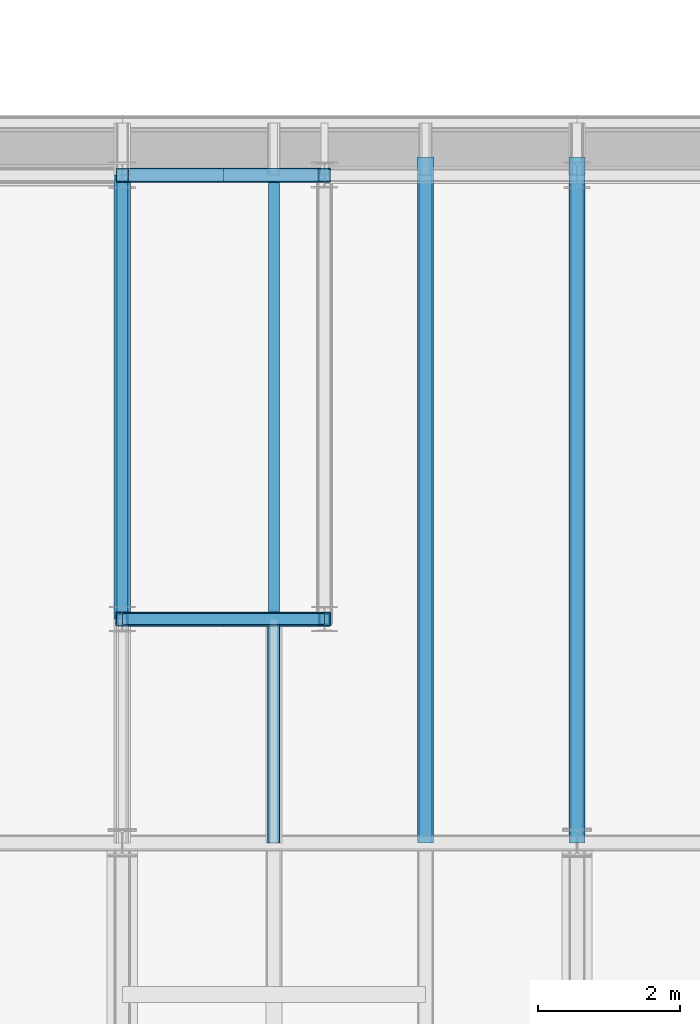
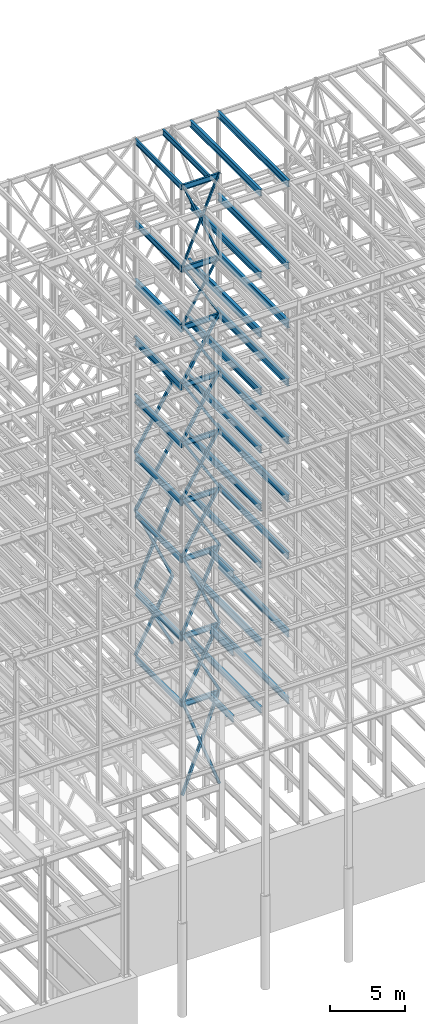
# One storey, part 141 of 150: 67 beams.
"""IFC2X3 building model written with IfcOpenShell, lengths in millimetres."""

import ifcopenshell
import ifcopenshell.guid

model = None  # the IFC model being written
_history = None  # IfcOwnerHistory: only IFC2X3 demands one
_inside = {}  # id of a spatial element -> (the spatial element, [elements in it])
_under = {}  # id of a project, library or spatial element -> (it, [spatial elements below it])
_declared = {}  # id of a project -> (the project, [libraries it declares])
_typed = {}  # id of a type object -> (the type object, [elements of that type])
_made_of = {}  # id of a material, layer set ... -> (it, [elements and type objects made of it])


def new_model(schema):
    """Start an empty IFC model of exactly this schema.

    Asked for "IFC4X3", IfcOpenShell would pick the latest addendum, in which some entities
    have other attributes; the version numbers below select the first issue.
    IFC2X3 requires an IfcOwnerHistory on every rooted entity: one is made here for all.
    """
    global model, _history
    if schema == "IFC4X3":
        model = ifcopenshell.file(schema_version=(4, 3, 0, 0))
    else:
        model = ifcopenshell.file(schema=schema)
    _inside.clear()
    _under.clear()
    _declared.clear()
    _typed.clear()
    _made_of.clear()
    _history = None
    if model.schema == "IFC2X3":
        org = make("IfcOrganization", Name="unknown")
        user = make(
            "IfcPersonAndOrganization",
            ThePerson=make("IfcPerson", FamilyName="unknown"),
            TheOrganization=org,
        )
        app = make(
            "IfcApplication",
            ApplicationDeveloper=org,
            Version="unknown",
            ApplicationFullName="unknown",
            ApplicationIdentifier="unknown",
        )
        _history = make(
            "IfcOwnerHistory",
            OwningUser=user,
            OwningApplication=app,
            ChangeAction="ADDED",
            CreationDate=0,
        )
    return model


def make(cls, **values):
    """One entity of the class cls with the attributes given. An attribute that is None is left unset."""
    return model.create_entity(
        cls, **{name: value for name, value in values.items() if value is not None}
    )


def rooted(cls, **values):
    """An entity with a GlobalId (a new one), such as an element, a storey or a relation."""
    return make(cls, GlobalId=ifcopenshell.guid.new(), OwnerHistory=_history, **values)


def si_unit(unit_type, name, prefix=None):
    """IfcSIUnit, for example si_unit("LENGTHUNIT", "METRE", prefix="MILLI")."""
    return make("IfcSIUnit", UnitType=unit_type, Prefix=prefix, Name=name)


def assignment(units):
    """IfcUnitAssignment: the units of a project."""
    return None if units is None else make("IfcUnitAssignment", Units=units)


def point(xyz):
    """IfcCartesianPoint."""
    return None if xyz is None else make("IfcCartesianPoint", Coordinates=xyz)


def direction(xyz):
    """IfcDirection."""
    return None if xyz is None else make("IfcDirection", DirectionRatios=xyz)


def frame(location, z_axis=None, x_axis=None):
    """IfcAxis2Placement3D, a coordinate frame: its origin and axes. An axis left out is left unset."""
    return make(
        "IfcAxis2Placement3D",
        Location=point(location),
        Axis=direction(z_axis),
        RefDirection=direction(x_axis),
    )


def frame_2d(location, x_axis=None):
    """IfcAxis2Placement2D, a coordinate frame in the plane: its origin and x axis."""
    return make(
        "IfcAxis2Placement2D", Location=point(location), RefDirection=direction(x_axis)
    )


def origin_with_axes():
    """The frame at (0, 0, 0) with the z axis (0, 0, 1) and the x axis (1, 0, 0) written out."""
    return frame((0.0, 0.0, 0.0), z_axis=(0.0, 0.0, 1.0), x_axis=(1.0, 0.0, 0.0))


def origin_2d_with_axis():
    """The frame at (0, 0) in the plane with the x axis (1, 0) written out."""
    return frame_2d((0.0, 0.0), x_axis=(1.0, 0.0))


def place(relative_to, where):
    """IfcLocalPlacement: puts the frame where relative to a parent placement (None: the world)."""
    return make(
        "IfcLocalPlacement", PlacementRelTo=relative_to, RelativePlacement=where
    )


def context(
    kind, dimensions, precision=None, world=None, true_north=None, identifier=None
):
    """IfcGeometricRepresentationContext, for example the 3D "Model" context."""
    return make(
        "IfcGeometricRepresentationContext",
        ContextIdentifier=identifier,
        ContextType=kind,
        CoordinateSpaceDimension=dimensions,
        Precision=precision,
        WorldCoordinateSystem=world,
        TrueNorth=true_north,
    )


def subcontext(parent, identifier, kind, view, scale=None):
    """IfcGeometricRepresentationSubContext, for example "Body" below "Model"."""
    return make(
        "IfcGeometricRepresentationSubContext",
        ContextIdentifier=identifier,
        ContextType=kind,
        ParentContext=parent,
        TargetScale=scale,
        TargetView=view,
    )


def project(units=None, contexts=None):
    """IfcProject with its units and contexts."""
    return rooted(
        "IfcProject",
        Name="project",
        RepresentationContexts=contexts,
        UnitsInContext=assignment(units),
    )


def spatial(cls, under=None, at=None, **own):
    """A site, building, storey or space (cls), placed at a placement, below another one or the project."""
    s = rooted(cls, ObjectPlacement=at, **own)
    if under is not None:
        _under.setdefault(under.id(), (under, []))[1].append(s)
    return s


def profile(cls, at=None, kind="AREA", **sizes):
    """A parametric profile (cls). Its sizes go by their IFC names, for example OverallWidth=200.0."""
    return make(cls, ProfileType=kind, Position=at, **sizes)


def hollow_rectangle(**sizes):
    """IfcRectangleHollowProfileDef."""
    return profile("IfcRectangleHollowProfileDef", **sizes)


def i_section(**sizes):
    """IfcIShapeProfileDef."""
    return profile("IfcIShapeProfileDef", **sizes)


def extrude(swept, where, along, depth):
    """IfcExtrudedAreaSolid: the profile swept, set in the frame where, extruded along a direction by depth."""
    return make(
        "IfcExtrudedAreaSolid",
        SweptArea=swept,
        Position=where,
        ExtrudedDirection=direction(along),
        Depth=depth,
    )


def shape(context_of_items, identifier, shape_type, items):
    """IfcShapeRepresentation: the items that make up one representation, for example the "Body"."""
    return make(
        "IfcShapeRepresentation",
        ContextOfItems=context_of_items,
        RepresentationIdentifier=identifier,
        RepresentationType=shape_type,
        Items=items,
    )


def material(Name=None, Category=None):
    """IfcMaterial."""
    return make("IfcMaterial", Name=Name, Category=Category)


def made_of(thing, what):
    """Note that an element or type object is made of a material, layer set ...; save() writes the relation."""
    if what is not None:
        _made_of.setdefault(what.id(), (what, []))[1].append(thing)
    return thing


def type_object(cls, material=None, **own):
    """A type object (cls), such as IfcWallType, which elements share."""
    return made_of(rooted(cls, **own), material)


def element(
    cls,
    number,
    at=None,
    inside=None,
    cuts=None,
    type_object=None,
    material=None,
    context=None,
    identifier="Body",
    shape_type=None,
    held_by="IfcProductDefinitionShape",
    body=None,
    shapes=None,
    **own,
):
    """One element of the class cls, such as IfcWall. Its Tag is "e" and its number.

    at: its placement. inside: the storey or other place that contains it. cuts: it is an
    opening in that element (IfcRelVoidsElement). A single representation is given by context,
    identifier, shape_type and body (its items); several are given by shapes. held_by: the class
    of the entity that holds the representations. save() writes the other relations.
    """
    e = rooted(cls, Tag="e%d" % number, ObjectPlacement=at, **own)
    if body is not None:
        shapes = [shape(context, identifier, shape_type, body)]
    if shapes is not None:
        e.Representation = make(held_by, Representations=shapes)
    if inside is not None:
        _inside.setdefault(inside.id(), (inside, []))[1].append(e)
    if cuts is not None:
        rooted(
            "IfcRelVoidsElement", RelatingBuildingElement=cuts, RelatedOpeningElement=e
        )
    if type_object is not None:
        _typed.setdefault(type_object.id(), (type_object, []))[1].append(e)
    return made_of(e, material)


def aggregate(whole, parts):
    """IfcRelAggregates: a whole, such as a stair, and the parts it consists of."""
    return rooted("IfcRelAggregates", RelatingObject=whole, RelatedObjects=parts)


def save(model, path):
    """Write the relations noted so far, then the file.

    IfcRelAggregates (storeys below a building ...), IfcRelContainedInSpatialStructure (elements
    in a storey), IfcRelDefinesByType, IfcRelAssociatesMaterial and IfcRelDeclares: one each for
    every whole, place, type object, material and project.
    """
    for whole, parts in _under.values():
        aggregate(whole, parts)
    for where, things in _inside.values():
        rooted(
            "IfcRelContainedInSpatialStructure",
            RelatedElements=things,
            RelatingStructure=where,
        )
    for kind, things in _typed.values():
        rooted("IfcRelDefinesByType", RelatedObjects=things, RelatingType=kind)
    for what, things in _made_of.values():
        rooted("IfcRelAssociatesMaterial", RelatedObjects=things, RelatingMaterial=what)
    for by, libraries in _declared.values():
        rooted("IfcRelDeclares", RelatingContext=by, RelatedDefinitions=libraries)
    model.write(path)


model = new_model("IFC2X3")

# Units and contexts
model_context = context("Model", 3, precision=1e-05, world=origin_with_axes())
body_context = subcontext(model_context, "Body", "Model", "MODEL_VIEW")
ifc_project = project(units=[si_unit("LENGTHUNIT", "METRE", prefix="MILLI"), si_unit("AREAUNIT", "SQUARE_METRE"), si_unit("VOLUMEUNIT", "CUBIC_METRE"), si_unit("MASSUNIT", "GRAM", prefix="KILO"), si_unit("TIMEUNIT", "SECOND"), si_unit("PLANEANGLEUNIT", "RADIAN"), si_unit("SOLIDANGLEUNIT", "STERADIAN"), si_unit("THERMODYNAMICTEMPERATUREUNIT", "DEGREE_CELSIUS"), si_unit("LUMINOUSINTENSITYUNIT", "LUMEN")], contexts=[model_context])

# Site, building, storey
site_placement = place(None, origin_with_axes())
site = spatial("IfcSite", under=ifc_project, at=site_placement, CompositionType="ELEMENT")
building_placement = place(site_placement, origin_with_axes())
building = spatial("IfcBuilding", under=site, at=building_placement, Name="Undefined", CompositionType="ELEMENT")
storey_placement = place(building_placement, origin_with_axes())
storey = spatial("IfcBuildingStorey", under=building, at=storey_placement, Name="Undefined", CompositionType="ELEMENT", Elevation=0.0)

# Beams
ifc_material_1 = material()
beam_type_1 = type_object("IfcBeamType", Name="HSS8X8X3/8", PredefinedType="NOTDEFINED")
beam_1_placement = place(storey_placement, frame((62992.0, 25628.6, 23774.4), z_axis=(-0.88862065311074, 0.0, 0.458642927411993), x_axis=(0.458642927411995, 0.0, 0.888620653110738)))
element("IfcBeam", 1, at=beam_1_placement, inside=storey, type_object=beam_type_1, material=ifc_material_1, Name="BEAM", ObjectType="HSS8X8X3/8", context=body_context, shape_type="SweptSolid", body=[
    extrude(hollow_rectangle(XDim=203.2, YDim=203.2, WallThickness=9.525, InnerFilletRadius=9.5249, OuterFilletRadius=19.0499, at=origin_2d_with_axis()), frame((6202.64671571741, 3.63797880709171e-12, 7.27595761418343e-12), z_axis=(-1.0, 0.0, 0.0), x_axis=(0.0, -1.0, 0.0)), (0.0, 0.0, 1.0), 6202.64671571741),
])
beam_2_placement = place(storey_placement, frame((65836.8, 25628.6, 29286.2), z_axis=(0.911370591188493, 0.0, 0.4115867411819), x_axis=(-0.411586741181902, 0.0, 0.911370591188492)))
element("IfcBeam", 2, at=beam_2_placement, inside=storey, type_object=beam_type_1, material=ifc_material_1, Name="BEAM", ObjectType="HSS8X8X3/8", context=body_context, shape_type="SweptSolid", body=[
    extrude(hollow_rectangle(XDim=203.2, YDim=203.2, WallThickness=9.525, InnerFilletRadius=9.5249, OuterFilletRadius=19.0499, at=origin_2d_with_axis()), frame((6911.78758932883, 0.0, 0.0), z_axis=(-1.0, 0.0, 0.0), x_axis=(0.0, -1.0, 0.0)), (0.0, 0.0, 1.0), 6911.78758932883),
])
for number, where, z_axis, x_axis, name in (
    (3, (62992.0, 25628.6, 35585.4), (-0.856679076231124, 0.0, 0.515849745902611), (0.51584974590261, 0.0, 0.856679076231124), "BEAM"),
    (4, (65836.8, 25628.6, 40309.8), (0.856679076231126, 0.0, 0.515849745902608), (-0.515849745902611, 0.0, 0.856679076231124), "BEAM"),
):
    element("IfcBeam", number, at=place(storey_placement, frame(where, z_axis=z_axis, x_axis=x_axis)), inside=storey, type_object=beam_type_1, material=ifc_material_1, Name=name, ObjectType="HSS8X8X3/8", context=body_context, shape_type="SweptSolid", body=[
        extrude(hollow_rectangle(XDim=203.2, YDim=203.2, WallThickness=9.525, InnerFilletRadius=9.5249, OuterFilletRadius=19.0499, at=origin_2d_with_axis()), frame((5514.78398489006, -3.63797880709171e-12, 0.0), z_axis=(-1.0, 0.0, 0.0), x_axis=(0.0, -1.0, 0.0)), (0.0, 0.0, 1.0), 5514.78398489006),
    ])
for number, where, z_axis, x_axis, name in (
    (5, (62992.0, 25628.6, 40309.8), (-0.856679076231124, 0.0, 0.515849745902611), (0.51584974590261, 0.0, 0.856679076231124), "BEAM"),
    (6, (65836.8, 25628.6, 35585.4), (0.856679076231126, 0.0, 0.515849745902608), (-0.515849745902611, 0.0, 0.856679076231124), "BEAM"),
):
    element("IfcBeam", number, at=place(storey_placement, frame(where, z_axis=z_axis, x_axis=x_axis)), inside=storey, type_object=beam_type_1, material=ifc_material_1, Name=name, ObjectType="HSS8X8X3/8", context=body_context, shape_type="SweptSolid", body=[
        extrude(hollow_rectangle(XDim=203.2, YDim=203.2, WallThickness=9.525, InnerFilletRadius=9.5249, OuterFilletRadius=19.0499, at=origin_2d_with_axis()), frame((5514.78398489006, -3.63797880709171e-12, 0.0), z_axis=(-1.0, 0.0, 0.0), x_axis=(0.0, -1.0, 0.0)), (0.0, 0.0, 1.0), 5514.78398489007),
    ])
beam_3_placement = place(storey_placement, frame((62992.0, 25628.6, 29286.2), z_axis=(-0.911370591188492, 0.0, 0.411586741181903), x_axis=(0.411586741181901, 0.0, 0.911370591188493)))
element("IfcBeam", 7, at=beam_3_placement, inside=storey, type_object=beam_type_1, material=ifc_material_1, Name="BEAM", ObjectType="HSS8X8X3/8", context=body_context, shape_type="SweptSolid", body=[
    extrude(hollow_rectangle(XDim=203.2, YDim=203.2, WallThickness=9.525, InnerFilletRadius=9.5249, OuterFilletRadius=19.0499, at=origin_2d_with_axis()), frame((6911.78758932883, 0.0, 0.0), z_axis=(-1.0, 0.0, 0.0), x_axis=(0.0, -1.0, 0.0)), (0.0, 0.0, 1.0), 6911.78758932882),
])
beam_4_placement = place(storey_placement, frame((65836.8, 25628.6, 23774.4), z_axis=(0.888620653110738, 0.0, 0.458642927411996), x_axis=(-0.458642927411995, 0.0, 0.888620653110739)))
element("IfcBeam", 8, at=beam_4_placement, inside=storey, type_object=beam_type_1, material=ifc_material_1, Name="BEAM", ObjectType="HSS8X8X3/8", context=body_context, shape_type="SweptSolid", body=[
    extrude(hollow_rectangle(XDim=203.2, YDim=203.2, WallThickness=9.525, InnerFilletRadius=9.5249, OuterFilletRadius=19.0499, at=origin_2d_with_axis()), frame((6202.64671571741, 3.63797880709171e-12, 7.27595761418343e-12), z_axis=(-1.0, 0.0, 0.0), x_axis=(0.0, -1.0, 0.0)), (0.0, 0.0, 1.0), 6202.64671571741),
])
beam_5_placement = place(storey_placement, frame((65836.8, 31877.0, 35585.4), z_axis=(0.856679076231126, 0.0, 0.515849745902608), x_axis=(-0.515849745902611, 0.0, 0.856679076231124)))
element("IfcBeam", 9, at=beam_5_placement, inside=storey, type_object=beam_type_1, material=ifc_material_1, Name="BEAM", ObjectType="HSS8X8X3/8", context=body_context, shape_type="SweptSolid", body=[
    extrude(hollow_rectangle(XDim=203.2, YDim=203.2, WallThickness=9.525, InnerFilletRadius=9.5249, OuterFilletRadius=19.0499, at=origin_2d_with_axis()), frame((5514.78398489006, -3.63797880709171e-12, 0.0), z_axis=(-1.0, 0.0, 0.0), x_axis=(0.0, -1.0, 0.0)), (0.0, 0.0, 1.0), 5514.78398489007),
])
for number, where, z_axis, x_axis, name in (
    (10, (62992.0, 31877.0, 35585.4), (-0.856679076231124, 0.0, 0.515849745902611), (0.51584974590261, 0.0, 0.856679076231124), "BEAM"),
    (11, (65836.8, 31877.0, 40309.8), (0.856679076231126, 0.0, 0.515849745902608), (-0.515849745902611, 0.0, 0.856679076231124), "BEAM"),
):
    element("IfcBeam", number, at=place(storey_placement, frame(where, z_axis=z_axis, x_axis=x_axis)), inside=storey, type_object=beam_type_1, material=ifc_material_1, Name=name, ObjectType="HSS8X8X3/8", context=body_context, shape_type="SweptSolid", body=[
        extrude(hollow_rectangle(XDim=203.2, YDim=203.2, WallThickness=9.525, InnerFilletRadius=9.5249, OuterFilletRadius=19.0499, at=origin_2d_with_axis()), frame((5514.78398489006, -3.63797880709171e-12, 0.0), z_axis=(-1.0, 0.0, 0.0), x_axis=(0.0, -1.0, 0.0)), (0.0, 0.0, 1.0), 5514.78398489006),
    ])
beam_6_placement = place(storey_placement, frame((62992.0, 31877.0, 40309.8), z_axis=(-0.856679076231124, 0.0, 0.515849745902611), x_axis=(0.51584974590261, 0.0, 0.856679076231124)))
element("IfcBeam", 12, at=beam_6_placement, inside=storey, type_object=beam_type_1, material=ifc_material_1, Name="BEAM", ObjectType="HSS8X8X3/8", context=body_context, shape_type="SweptSolid", body=[
    extrude(hollow_rectangle(XDim=203.2, YDim=203.2, WallThickness=9.525, InnerFilletRadius=9.5249, OuterFilletRadius=19.0499, at=origin_2d_with_axis()), frame((5514.78398489006, -3.63797880709171e-12, 0.0), z_axis=(-1.0, 0.0, 0.0), x_axis=(0.0, -1.0, 0.0)), (0.0, 0.0, 1.0), 5514.78398489007),
])
ifc_material_2 = material(Name="STEEL/A992")
beam_type_2 = type_object("IfcBeamType", Name="W18X35", PredefinedType="NOTDEFINED")
beam_7_placement = place(storey_placement, frame((65125.6, 25628.6, 65687.575), z_axis=(0.0, 0.0, 1.0), x_axis=(0.0, 1.0, 0.0)))
element("IfcBeam", 13, at=beam_7_placement, inside=storey, type_object=beam_type_2, material=ifc_material_2, Name="BEAM", ObjectType="W18X35", context=body_context, shape_type="SweptSolid", body=[
    extrude(i_section(OverallWidth=152.4, OverallDepth=450.85, WebThickness=7.9375, FlangeThickness=10.795, FilletRadius=17.78, at=origin_2d_with_axis()), frame((6248.40000000001, 0.0, 0.0), z_axis=(-1.0, 0.0, 0.0), x_axis=(0.0, -1.0, 0.0)), (0.0, 0.0, 1.0), 6248.40000000001),
])
beam_8_placement = place(storey_placement, frame((62992.0, 25628.6, 65687.575), z_axis=(0.0, 0.0, 1.0), x_axis=(1.0, 0.0, 0.0)))
element("IfcBeam", 14, at=beam_8_placement, inside=storey, type_object=beam_type_2, material=ifc_material_2, Name="BEAM", ObjectType="W18X35", context=body_context, shape_type="SweptSolid", body=[
    extrude(i_section(OverallWidth=152.4, OverallDepth=450.85, WebThickness=7.9375, FlangeThickness=10.795, FilletRadius=17.78, at=origin_2d_with_axis()), frame((2844.8, 0.0, 0.0), z_axis=(-1.0, 0.0, 0.0), x_axis=(0.0, -1.0, 0.0)), (0.0, 0.0, 1.0), 2844.8),
])
beam_9_placement = place(storey_placement, frame((62992.0, 25628.6, 65687.575), z_axis=(0.0, 0.0, 1.0), x_axis=(0.0, 1.0, 0.0)))
element("IfcBeam", 15, at=beam_9_placement, inside=storey, type_object=beam_type_2, material=ifc_material_2, Name="BEAM", ObjectType="W18X35", context=body_context, shape_type="SweptSolid", body=[
    extrude(i_section(OverallWidth=152.4, OverallDepth=450.85, WebThickness=7.9375, FlangeThickness=10.795, FilletRadius=17.78, at=origin_2d_with_axis()), frame((6248.40000000001, 0.0, 0.0), z_axis=(-1.0, 0.0, 0.0), x_axis=(0.0, -1.0, 0.0)), (0.0, 0.0, 1.0), 6248.40000000001),
])
beam_10_placement = place(storey_placement, frame((62992.0, 25628.6, 58981.975), z_axis=(0.0, 0.0, 1.0), x_axis=(1.0, 0.0, 0.0)))
element("IfcBeam", 16, at=beam_10_placement, inside=storey, type_object=beam_type_2, material=ifc_material_2, Name="BEAM", ObjectType="W18X35", context=body_context, shape_type="SweptSolid", body=[
    extrude(i_section(OverallWidth=152.4, OverallDepth=450.85, WebThickness=7.9375, FlangeThickness=10.795, FilletRadius=17.78, at=origin_2d_with_axis()), frame((2844.8, 0.0, 0.0), z_axis=(-1.0, 0.0, 0.0), x_axis=(0.0, -1.0, 0.0)), (0.0, 0.0, 1.0), 2844.8),
])
beam_11_placement = place(storey_placement, frame((62992.0, 25628.6, 58981.975), z_axis=(0.0, 0.0, 1.0), x_axis=(0.0, 1.0, 0.0)))
element("IfcBeam", 17, at=beam_11_placement, inside=storey, type_object=beam_type_2, material=ifc_material_2, Name="BEAM", ObjectType="W18X35", context=body_context, shape_type="SweptSolid", body=[
    extrude(i_section(OverallWidth=152.4, OverallDepth=450.85, WebThickness=7.9375, FlangeThickness=10.795, FilletRadius=17.78, at=origin_2d_with_axis()), frame((6248.40000000001, 0.0, 0.0), z_axis=(-1.0, 0.0, 0.0), x_axis=(0.0, -1.0, 0.0)), (0.0, 0.0, 1.0), 6248.40000000001),
])
for number, where, z_axis, x_axis, name in (
    (18, (62992.0, 25628.6, 54257.575), (0.0, 0.0, 1.0), (1.0, 0.0, 0.0), "BEAM"),
    (19, (62992.0, 25628.6, 49533.175), (0.0, 0.0, 1.0), (1.0, 0.0, 0.0), "BEAM"),
    (20, (62992.0, 25628.6, 44808.775), (0.0, 0.0, 1.0), (1.0, 0.0, 0.0), "BEAM"),
    (21, (62992.0, 25628.6, 40084.375), (0.0, 0.0, 1.0), (1.0, 0.0, 0.0), "BEAM"),
    (22, (62992.0, 25628.6, 35359.975), (0.0, 0.0, 1.0), (1.0, 0.0, 0.0), "BEAM"),
    (23, (62992.0, 25628.6, 29060.775), (0.0, 0.0, 1.0), (1.0, 0.0, 0.0), "BEAM"),
):
    element("IfcBeam", number, at=place(storey_placement, frame(where, z_axis=z_axis, x_axis=x_axis)), inside=storey, type_object=beam_type_2, material=ifc_material_2, Name=name, ObjectType="W18X35", context=body_context, shape_type="SweptSolid", body=[
        extrude(i_section(OverallWidth=152.4, OverallDepth=450.85, WebThickness=7.9375, FlangeThickness=10.795, FilletRadius=17.78, at=origin_2d_with_axis()), frame((2844.8, 0.0, 0.0), z_axis=(-1.0, 0.0, 0.0), x_axis=(0.0, -1.0, 0.0)), (0.0, 0.0, 1.0), 2844.8),
    ])
beam_12_placement = place(storey_placement, frame((62992.0, 25628.6, 23548.975), z_axis=(0.0, 0.0, 1.0), x_axis=(0.0, 1.0, 0.0)))
element("IfcBeam", 24, at=beam_12_placement, inside=storey, type_object=beam_type_2, material=ifc_material_2, Name="BEAM", ObjectType="W18X35", context=body_context, shape_type="SweptSolid", body=[
    extrude(i_section(OverallWidth=152.4, OverallDepth=450.85, WebThickness=7.9375, FlangeThickness=10.795, FilletRadius=17.78, at=origin_2d_with_axis()), frame((6248.40000000001, 0.0, 0.0), z_axis=(-1.0, 0.0, 0.0), x_axis=(0.0, -1.0, 0.0)), (0.0, 0.0, 1.0), 6248.40000000001),
])
beam_13_placement = place(storey_placement, frame((62992.0, 25628.6, 23548.975), z_axis=(0.0, 0.0, 1.0), x_axis=(1.0, 0.0, 0.0)))
element("IfcBeam", 25, at=beam_13_placement, inside=storey, type_object=beam_type_2, material=ifc_material_2, Name="BEAM", ObjectType="W18X35", context=body_context, shape_type="SweptSolid", body=[
    extrude(i_section(OverallWidth=152.4, OverallDepth=450.85, WebThickness=7.9375, FlangeThickness=10.795, FilletRadius=17.78, at=origin_2d_with_axis()), frame((2844.8, 0.0, 0.0), z_axis=(-1.0, 0.0, 0.0), x_axis=(0.0, -1.0, 0.0)), (0.0, 0.0, 1.0), 2844.8),
])
beam_type_3 = type_object("IfcBeamType", Name="HSS8X8X1/4", PredefinedType="NOTDEFINED")
beam_14_placement = place(storey_placement, frame((62992.0, 25628.6, 45034.2), z_axis=(-0.856679076231124, 0.0, 0.515849745902611), x_axis=(0.51584974590261, 0.0, 0.856679076231124)))
element("IfcBeam", 26, at=beam_14_placement, inside=storey, type_object=beam_type_3, material=ifc_material_1, Name="BEAM", ObjectType="HSS8X8X1/4", context=body_context, shape_type="SweptSolid", body=[
    extrude(hollow_rectangle(XDim=203.2, YDim=203.2, WallThickness=6.35, InnerFilletRadius=6.3499, OuterFilletRadius=12.6999, at=origin_2d_with_axis()), frame((5514.78398489006, -3.63797880709171e-12, 0.0), z_axis=(-1.0, 0.0, 0.0), x_axis=(0.0, -1.0, 0.0)), (0.0, 0.0, 1.0), 5514.78398489007),
])
beam_15_placement = place(storey_placement, frame((65836.8, 25628.6, 49758.6), z_axis=(0.856679076231126, 0.0, 0.515849745902608), x_axis=(-0.515849745902611, 0.0, 0.856679076231124)))
element("IfcBeam", 27, at=beam_15_placement, inside=storey, type_object=beam_type_3, material=ifc_material_1, Name="BEAM", ObjectType="HSS8X8X1/4", context=body_context, shape_type="SweptSolid", body=[
    extrude(hollow_rectangle(XDim=203.2, YDim=203.2, WallThickness=6.35, InnerFilletRadius=6.3499, OuterFilletRadius=12.6999, at=origin_2d_with_axis()), frame((5514.78398489006, -3.63797880709171e-12, 0.0), z_axis=(-1.0, 0.0, 0.0), x_axis=(0.0, -1.0, 0.0)), (0.0, 0.0, 1.0), 5514.78398489006),
])
beam_16_placement = place(storey_placement, frame((62992.0, 25628.6, 49758.6), z_axis=(-0.856679076231124, 0.0, 0.515849745902611), x_axis=(0.51584974590261, 0.0, 0.856679076231124)))
element("IfcBeam", 28, at=beam_16_placement, inside=storey, type_object=beam_type_3, material=ifc_material_1, Name="BEAM", ObjectType="HSS8X8X1/4", context=body_context, shape_type="SweptSolid", body=[
    extrude(hollow_rectangle(XDim=203.2, YDim=203.2, WallThickness=6.35, InnerFilletRadius=6.3499, OuterFilletRadius=12.6999, at=origin_2d_with_axis()), frame((5514.78398489006, -3.63797880709171e-12, 0.0), z_axis=(-1.0, 0.0, 0.0), x_axis=(0.0, -1.0, 0.0)), (0.0, 0.0, 1.0), 5514.78398489008),
])
beam_17_placement = place(storey_placement, frame((65836.7996641932, 25628.6, 45034.1996294296), z_axis=(0.856679076231126, 0.0, 0.515849745902608), x_axis=(-0.515849745902611, 0.0, 0.856679076231124)))
element("IfcBeam", 29, at=beam_17_placement, inside=storey, type_object=beam_type_3, material=ifc_material_1, Name="BEAM", ObjectType="HSS8X8X1/4", context=body_context, shape_type="SweptSolid", body=[
    extrude(hollow_rectangle(XDim=203.2, YDim=203.2, WallThickness=6.35, InnerFilletRadius=6.3499, OuterFilletRadius=12.6999, at=origin_2d_with_axis()), frame((5514.78412912414, -3.63797880709171e-12, 0.0), z_axis=(-1.0, 0.0, 0.0), x_axis=(0.0, -1.0, 0.0)), (0.0, 0.0, 1.0), 5514.78412912414),
])
beam_18_placement = place(storey_placement, frame((65836.8, 31877.0, 45034.2), z_axis=(0.856679076231126, 0.0, 0.515849745902608), x_axis=(-0.515849745902611, 0.0, 0.856679076231124)))
element("IfcBeam", 30, at=beam_18_placement, inside=storey, type_object=beam_type_3, material=ifc_material_1, Name="BEAM", ObjectType="HSS8X8X1/4", context=body_context, shape_type="SweptSolid", body=[
    extrude(hollow_rectangle(XDim=203.2, YDim=203.2, WallThickness=6.35, InnerFilletRadius=6.3499, OuterFilletRadius=12.6999, at=origin_2d_with_axis()), frame((5514.78398489006, -3.63797880709171e-12, 0.0), z_axis=(-1.0, 0.0, 0.0), x_axis=(0.0, -1.0, 0.0)), (0.0, 0.0, 1.0), 5514.78398489006),
])
beam_type_4 = type_object("IfcBeamType", Name="HSS8X8X1/2", PredefinedType="NOTDEFINED")
beam_19_placement = place(storey_placement, frame((65836.8, 31877.0, 23774.4), z_axis=(0.888620653110738, 0.0, 0.458642927411996), x_axis=(-0.458642927411995, 0.0, 0.888620653110739)))
element("IfcBeam", 31, at=beam_19_placement, inside=storey, type_object=beam_type_4, material=ifc_material_1, Name="BEAM", ObjectType="HSS8X8X1/2", context=body_context, shape_type="SweptSolid", body=[
    extrude(hollow_rectangle(XDim=203.2, YDim=203.2, WallThickness=12.7, InnerFilletRadius=12.6999, OuterFilletRadius=25.3999, at=origin_2d_with_axis()), frame((6202.64671571741, 3.63797880709171e-12, 7.27595761418343e-12), z_axis=(-1.0, 0.0, 0.0), x_axis=(0.0, -1.0, 0.0)), (0.0, 0.0, 1.0), 6202.6467157174),
])
beam_20_placement = place(storey_placement, frame((62992.0, 31877.0, 23774.4), z_axis=(-0.88862065311074, 0.0, 0.458642927411993), x_axis=(0.458642927411995, 0.0, 0.888620653110738)))
element("IfcBeam", 32, at=beam_20_placement, inside=storey, type_object=beam_type_4, material=ifc_material_1, Name="BEAM", ObjectType="HSS8X8X1/2", context=body_context, shape_type="SweptSolid", body=[
    extrude(hollow_rectangle(XDim=203.2, YDim=203.2, WallThickness=12.7, InnerFilletRadius=12.6999, OuterFilletRadius=25.3999, at=origin_2d_with_axis()), frame((6202.64671571741, 3.63797880709171e-12, 7.27595761418343e-12), z_axis=(-1.0, 0.0, 0.0), x_axis=(0.0, -1.0, 0.0)), (0.0, 0.0, 1.0), 6202.64671571741),
])
beam_21_placement = place(storey_placement, frame((65836.8, 31877.0, 29286.2), z_axis=(0.911370591188493, 0.0, 0.4115867411819), x_axis=(-0.411586741181902, 0.0, 0.911370591188492)))
element("IfcBeam", 33, at=beam_21_placement, inside=storey, type_object=beam_type_4, material=ifc_material_1, Name="BEAM", ObjectType="HSS8X8X1/2", context=body_context, shape_type="SweptSolid", body=[
    extrude(hollow_rectangle(XDim=203.2, YDim=203.2, WallThickness=12.7, InnerFilletRadius=12.6999, OuterFilletRadius=25.3999, at=origin_2d_with_axis()), frame((6911.78758932883, 0.0, 0.0), z_axis=(-1.0, 0.0, 0.0), x_axis=(0.0, -1.0, 0.0)), (0.0, 0.0, 1.0), 6911.78758932884),
])
beam_22_placement = place(storey_placement, frame((62992.0, 31877.0, 29286.2), z_axis=(-0.911370591188492, 0.0, 0.411586741181903), x_axis=(0.411586741181901, 0.0, 0.911370591188493)))
element("IfcBeam", 34, at=beam_22_placement, inside=storey, type_object=beam_type_4, material=ifc_material_1, Name="BEAM", ObjectType="HSS8X8X1/2", context=body_context, shape_type="SweptSolid", body=[
    extrude(hollow_rectangle(XDim=203.2, YDim=203.2, WallThickness=12.7, InnerFilletRadius=12.6999, OuterFilletRadius=25.3999, at=origin_2d_with_axis()), frame((6911.78758932883, 0.0, 0.0), z_axis=(-1.0, 0.0, 0.0), x_axis=(0.0, -1.0, 0.0)), (0.0, 0.0, 1.0), 6911.78758932882),
])
beam_type_5 = type_object("IfcBeamType", Name="HSS6X6X1/4", PredefinedType="NOTDEFINED")
beam_23_placement = place(storey_placement, frame((62992.0, 25628.6, 54483.0), z_axis=(-0.856679076231124, 0.0, 0.515849745902611), x_axis=(0.51584974590261, 0.0, 0.856679076231124)))
element("IfcBeam", 35, at=beam_23_placement, inside=storey, type_object=beam_type_5, material=ifc_material_1, Name="BEAM", ObjectType="HSS6X6X1/4", context=body_context, shape_type="SweptSolid", body=[
    extrude(hollow_rectangle(XDim=152.4, YDim=152.4, WallThickness=6.35, InnerFilletRadius=6.3499, OuterFilletRadius=12.6999, at=origin_2d_with_axis()), frame((5514.78398489006, -3.63797880709171e-12, 0.0), z_axis=(-1.0, 0.0, 0.0), x_axis=(0.0, -1.0, 0.0)), (0.0, 0.0, 1.0), 5514.78398489007),
])
for number, where, z_axis, x_axis, name in (
    (36, (65836.8, 25628.6, 59207.4), (0.920581786233233, 0.0, 0.390549836583797), (-0.390549836583795, 0.0, 0.920581786233234), "BEAM"),
    (37, (62992.0, 25628.6, 59207.4), (-0.920581786233234, 0.0, 0.390549836583795), (0.390549836583795, 0.0, 0.920581786233234), "BEAM"),
):
    element("IfcBeam", number, at=place(storey_placement, frame(where, z_axis=z_axis, x_axis=x_axis)), inside=storey, type_object=beam_type_5, material=ifc_material_1, Name=name, ObjectType="HSS6X6X1/4", context=body_context, shape_type="SweptSolid", body=[
        extrude(hollow_rectangle(XDim=152.4, YDim=152.4, WallThickness=6.35, InnerFilletRadius=6.3499, OuterFilletRadius=12.6999, at=origin_2d_with_axis()), frame((7284.08940087915, 0.0, -4.04348188314205e-13), z_axis=(-1.0, 0.0, 0.0), x_axis=(0.0, -1.0, 0.0)), (0.0, 0.0, 1.0), 7284.08940087915),
    ])
beam_24_placement = place(storey_placement, frame((65836.7996641932, 25628.6, 54482.9996294296), z_axis=(0.856679076231126, 0.0, 0.515849745902608), x_axis=(-0.515849745902611, 0.0, 0.856679076231124)))
element("IfcBeam", 38, at=beam_24_placement, inside=storey, type_object=beam_type_5, material=ifc_material_1, Name="BEAM", ObjectType="HSS6X6X1/4", context=body_context, shape_type="SweptSolid", body=[
    extrude(hollow_rectangle(XDim=152.4, YDim=152.4, WallThickness=6.35, InnerFilletRadius=6.3499, OuterFilletRadius=12.6999, at=origin_2d_with_axis()), frame((5514.78412912414, -3.63797880709171e-12, 0.0), z_axis=(-1.0, 0.0, 0.0), x_axis=(0.0, -1.0, 0.0)), (0.0, 0.0, 1.0), 5514.78412912414),
])
beam_type_6 = type_object("IfcBeamType", Name="HSS8X8X5/8", PredefinedType="NOTDEFINED")
beam_25_placement = place(storey_placement, frame((65836.8, 25628.6, 16154.4), z_axis=(0.936841534387209, 0.0, 0.349754112837891), x_axis=(-0.349754112837889, 0.0, 0.936841534387209)))
element("IfcBeam", 39, at=beam_25_placement, inside=storey, type_object=beam_type_6, material=ifc_material_1, Name="BEAM", ObjectType="HSS8X8X5/8", context=body_context, shape_type="SweptSolid", body=[
    extrude(hollow_rectangle(XDim=203.2, YDim=203.2, WallThickness=15.875, InnerFilletRadius=15.875, OuterFilletRadius=31.75, at=origin_2d_with_axis()), frame((8133.71299223178, 3.63797880709171e-12, 0.0), z_axis=(-1.0, 0.0, 0.0), x_axis=(0.0, -1.0, 0.0)), (0.0, 0.0, 1.0), 8133.71299223178),
])
beam_26_placement = place(storey_placement, frame((62992.0, 25628.6, 16154.4), z_axis=(-0.93684153438721, 0.0, 0.349754112837889), x_axis=(0.34975411283789, 0.0, 0.936841534387209)))
element("IfcBeam", 40, at=beam_26_placement, inside=storey, type_object=beam_type_6, material=ifc_material_1, Name="BEAM", ObjectType="HSS8X8X5/8", context=body_context, shape_type="SweptSolid", body=[
    extrude(hollow_rectangle(XDim=203.2, YDim=203.2, WallThickness=15.875, InnerFilletRadius=15.875, OuterFilletRadius=31.75, at=origin_2d_with_axis()), frame((8133.71299223178, 3.63797880709171e-12, 0.0), z_axis=(-1.0, 0.0, 0.0), x_axis=(0.0, -1.0, 0.0)), (0.0, 0.0, 1.0), 8133.71299223177),
])
beam_type_7 = type_object("IfcBeamType", Name="W24X68", PredefinedType="NOTDEFINED")
beam_27_placement = place(storey_placement, frame((62992.0, 25628.6, 54181.375), z_axis=(0.0, 0.0, 1.0), x_axis=(0.0, 1.0, 0.0)))
element("IfcBeam", 41, at=beam_27_placement, inside=storey, type_object=beam_type_7, material=ifc_material_2, Name="BEAM", ObjectType="W24X68", context=body_context, shape_type="SweptSolid", body=[
    extrude(i_section(OverallWidth=227.838, OverallDepth=603.25, WebThickness=11.1125, FlangeThickness=14.859, FilletRadius=23.2409, at=origin_2d_with_axis()), frame((6248.40000000001, 0.0, 0.0), z_axis=(-1.0, 0.0, 0.0), x_axis=(0.0, -1.0, 0.0)), (0.0, 0.0, 1.0), 6248.40000000001),
])
for number, where, z_axis, x_axis, name in (
    (42, (69392.8, 22479.0, 54181.375), (0.0, 0.0, 1.0), (0.0, 1.0, 0.0), "BEAM"),
    (43, (67259.2, 22479.0, 54181.375), (0.0, 0.0, 1.0), (0.0, 1.0, 0.0), "BEAM"),
):
    element("IfcBeam", number, at=place(storey_placement, frame(where, z_axis=z_axis, x_axis=x_axis)), inside=storey, type_object=beam_type_7, material=ifc_material_2, Name=name, ObjectType="W24X68", context=body_context, shape_type="SweptSolid", body=[
        extrude(i_section(OverallWidth=227.838, OverallDepth=603.25, WebThickness=11.1125, FlangeThickness=14.859, FilletRadius=23.2409, at=origin_2d_with_axis()), frame((9652.0, 0.0, 0.0), z_axis=(-1.0, 0.0, 0.0), x_axis=(0.0, -1.0, 0.0)), (0.0, 0.0, 1.0), 9652.0),
    ])
beam_28_placement = place(storey_placement, frame((62992.0, 25628.6, 49456.975), z_axis=(0.0, 0.0, 1.0), x_axis=(0.0, 1.0, 0.0)))
element("IfcBeam", 44, at=beam_28_placement, inside=storey, type_object=beam_type_7, material=ifc_material_2, Name="BEAM", ObjectType="W24X68", context=body_context, shape_type="SweptSolid", body=[
    extrude(i_section(OverallWidth=227.838, OverallDepth=603.25, WebThickness=11.1125, FlangeThickness=14.859, FilletRadius=23.2409, at=origin_2d_with_axis()), frame((6248.40000000001, 0.0, 0.0), z_axis=(-1.0, 0.0, 0.0), x_axis=(0.0, -1.0, 0.0)), (0.0, 0.0, 1.0), 6248.40000000001),
])
for number, where, z_axis, x_axis, name in (
    (45, (69392.8, 22479.0, 49456.975), (0.0, 0.0, 1.0), (0.0, 1.0, 0.0), "BEAM"),
    (46, (67259.2, 22479.0, 49456.975), (0.0, 0.0, 1.0), (0.0, 1.0, 0.0), "BEAM"),
):
    element("IfcBeam", number, at=place(storey_placement, frame(where, z_axis=z_axis, x_axis=x_axis)), inside=storey, type_object=beam_type_7, material=ifc_material_2, Name=name, ObjectType="W24X68", context=body_context, shape_type="SweptSolid", body=[
        extrude(i_section(OverallWidth=227.838, OverallDepth=603.25, WebThickness=11.1125, FlangeThickness=14.859, FilletRadius=23.2409, at=origin_2d_with_axis()), frame((9652.0, 0.0, 0.0), z_axis=(-1.0, 0.0, 0.0), x_axis=(0.0, -1.0, 0.0)), (0.0, 0.0, 1.0), 9652.0),
    ])
beam_29_placement = place(storey_placement, frame((62992.0, 25628.6, 44732.575), z_axis=(0.0, 0.0, 1.0), x_axis=(0.0, 1.0, 0.0)))
element("IfcBeam", 47, at=beam_29_placement, inside=storey, type_object=beam_type_7, material=ifc_material_2, Name="BEAM", ObjectType="W24X68", context=body_context, shape_type="SweptSolid", body=[
    extrude(i_section(OverallWidth=227.838, OverallDepth=603.25, WebThickness=11.1125, FlangeThickness=14.859, FilletRadius=23.2409, at=origin_2d_with_axis()), frame((6248.40000000001, 0.0, 0.0), z_axis=(-1.0, 0.0, 0.0), x_axis=(0.0, -1.0, 0.0)), (0.0, 0.0, 1.0), 6248.40000000001),
])
for number, where, z_axis, x_axis, name in (
    (48, (69392.8, 22479.0, 44732.575), (0.0, 0.0, 1.0), (0.0, 1.0, 0.0), "BEAM"),
    (49, (67259.2, 22479.0, 44732.575), (0.0, 0.0, 1.0), (0.0, 1.0, 0.0), "BEAM"),
):
    element("IfcBeam", number, at=place(storey_placement, frame(where, z_axis=z_axis, x_axis=x_axis)), inside=storey, type_object=beam_type_7, material=ifc_material_2, Name=name, ObjectType="W24X68", context=body_context, shape_type="SweptSolid", body=[
        extrude(i_section(OverallWidth=227.838, OverallDepth=603.25, WebThickness=11.1125, FlangeThickness=14.859, FilletRadius=23.2409, at=origin_2d_with_axis()), frame((9652.0, 0.0, 0.0), z_axis=(-1.0, 0.0, 0.0), x_axis=(0.0, -1.0, 0.0)), (0.0, 0.0, 1.0), 9652.0),
    ])
beam_30_placement = place(storey_placement, frame((62992.0, 25628.6, 40008.175), z_axis=(0.0, 0.0, 1.0), x_axis=(0.0, 1.0, 0.0)))
element("IfcBeam", 50, at=beam_30_placement, inside=storey, type_object=beam_type_7, material=ifc_material_2, Name="BEAM", ObjectType="W24X68", context=body_context, shape_type="SweptSolid", body=[
    extrude(i_section(OverallWidth=227.838, OverallDepth=603.25, WebThickness=11.1125, FlangeThickness=14.859, FilletRadius=23.2409, at=origin_2d_with_axis()), frame((6248.40000000001, 0.0, 0.0), z_axis=(-1.0, 0.0, 0.0), x_axis=(0.0, -1.0, 0.0)), (0.0, 0.0, 1.0), 6248.40000000001),
])
for number, where, z_axis, x_axis, name in (
    (51, (69392.8, 22479.0, 40008.175), (0.0, 0.0, 1.0), (0.0, 1.0, 0.0), "BEAM"),
    (52, (67259.2, 22479.0, 40008.175), (0.0, 0.0, 1.0), (0.0, 1.0, 0.0), "BEAM"),
):
    element("IfcBeam", number, at=place(storey_placement, frame(where, z_axis=z_axis, x_axis=x_axis)), inside=storey, type_object=beam_type_7, material=ifc_material_2, Name=name, ObjectType="W24X68", context=body_context, shape_type="SweptSolid", body=[
        extrude(i_section(OverallWidth=227.838, OverallDepth=603.25, WebThickness=11.1125, FlangeThickness=14.859, FilletRadius=23.2409, at=origin_2d_with_axis()), frame((9652.0, 0.0, 0.0), z_axis=(-1.0, 0.0, 0.0), x_axis=(0.0, -1.0, 0.0)), (0.0, 0.0, 1.0), 9652.0),
    ])
beam_type_8 = type_object("IfcBeamType", Name="W21X55", PredefinedType="NOTDEFINED")
for number, where, z_axis, x_axis, name in (
    (53, (69392.8, 22479.0, 65649.475), (0.0, 0.0, 1.0), (0.0, 1.0, 0.0), "BEAM"),
    (54, (67259.2, 22479.0, 65649.475), (0.0, 0.0, 1.0), (0.0, 1.0, 0.0), "BEAM"),
    (55, (69392.8, 22479.0, 58943.875), (0.0, 0.0, 1.0), (0.0, 1.0, 0.0), "BEAM"),
    (56, (67259.2, 22479.0, 58943.875), (0.0, 0.0, 1.0), (0.0, 1.0, 0.0), "BEAM"),
):
    element("IfcBeam", number, at=place(storey_placement, frame(where, z_axis=z_axis, x_axis=x_axis)), inside=storey, type_object=beam_type_8, material=ifc_material_2, Name=name, ObjectType="W21X55", context=body_context, shape_type="SweptSolid", body=[
        extrude(i_section(OverallWidth=208.788, OverallDepth=527.05, WebThickness=9.5, FlangeThickness=13.2588, FilletRadius=16.8624, at=origin_2d_with_axis()), frame((9398.0, 0.0, 0.0), z_axis=(-1.0, 0.0, 0.0), x_axis=(0.0, -1.0, 0.0)), (0.0, 0.0, 1.0), 9398.0),
    ])
beam_type_9 = type_object("IfcBeamType", Name="W24X55", PredefinedType="NOTDEFINED")
for number, where, z_axis, x_axis, name in (
    (57, (69392.8, 22479.0, 28986.1625), (0.0, 0.0, 1.0), (0.0, 1.0, 0.0), "BEAM"),
    (58, (67259.2, 22479.0, 28986.1625), (0.0, 0.0, 1.0), (0.0, 1.0, 0.0), "BEAM"),
):
    element("IfcBeam", number, at=place(storey_placement, frame(where, z_axis=z_axis, x_axis=x_axis)), inside=storey, type_object=beam_type_9, material=ifc_material_2, Name=name, ObjectType="W24X55", context=body_context, shape_type="SweptSolid", body=[
        extrude(i_section(OverallWidth=178.054, OverallDepth=600.075, WebThickness=9.5249, FlangeThickness=12.827, FilletRadius=23.6854, at=origin_2d_with_axis()), frame((9398.0, 0.0, 0.0), z_axis=(-1.0, 0.0, 0.0), x_axis=(0.0, -1.0, 0.0)), (0.0, 0.0, 1.0), 9398.00000000001),
    ])
beam_31_placement = place(storey_placement, frame((65125.6, 22479.0, 28986.1625), z_axis=(0.0, 0.0, 1.0), x_axis=(0.0, 1.0, 0.0)))
element("IfcBeam", 59, at=beam_31_placement, inside=storey, type_object=beam_type_9, material=ifc_material_2, Name="BEAM", ObjectType="W24X55", context=body_context, shape_type="SweptSolid", body=[
    extrude(i_section(OverallWidth=178.054, OverallDepth=600.075, WebThickness=9.5249, FlangeThickness=12.827, FilletRadius=23.6854, at=origin_2d_with_axis()), frame((3149.59968503999, 0.0, 0.0), z_axis=(-1.0, 0.0, 0.0), x_axis=(0.0, -1.0, 0.0)), (0.0, 0.0, 1.0), 3149.59968503999),
])
beam_32_placement = place(storey_placement, frame((62992.0, 25628.6, 28986.1625), z_axis=(0.0, 0.0, 1.0), x_axis=(0.0, 1.0, 0.0)))
element("IfcBeam", 60, at=beam_32_placement, inside=storey, type_object=beam_type_9, material=ifc_material_2, Name="BEAM", ObjectType="W24X55", context=body_context, shape_type="SweptSolid", body=[
    extrude(i_section(OverallWidth=178.054, OverallDepth=600.075, WebThickness=9.5249, FlangeThickness=12.827, FilletRadius=23.6854, at=origin_2d_with_axis()), frame((6248.40000000001, 0.0, 0.0), z_axis=(-1.0, 0.0, 0.0), x_axis=(0.0, -1.0, 0.0)), (0.0, 0.0, 1.0), 6248.40000000001),
])
beam_type_10 = type_object("IfcBeamType", Name="W21X44", PredefinedType="NOTDEFINED")
beam_33_placement = place(storey_placement, frame((62992.0, 25628.6, 35323.4625), z_axis=(0.0, 0.0, 1.0), x_axis=(0.0, 1.0, 0.0)))
element("IfcBeam", 61, at=beam_33_placement, inside=storey, type_object=beam_type_10, material=ifc_material_2, Name="BEAM", ObjectType="W21X44", context=body_context, shape_type="SweptSolid", body=[
    extrude(i_section(OverallWidth=165.1, OverallDepth=523.875, WebThickness=9.5249, FlangeThickness=11.43, FilletRadius=17.145, at=origin_2d_with_axis()), frame((6248.40000000001, 0.0, 0.0), z_axis=(-1.0, 0.0, 0.0), x_axis=(0.0, -1.0, 0.0)), (0.0, 0.0, 1.0), 6248.40000000001),
])
for number, where, z_axis, x_axis, name in (
    (62, (69392.8, 22479.0, 35323.4625), (0.0, 0.0, 1.0), (0.0, 1.0, 0.0), "BEAM"),
    (63, (67259.19935992, 22479.0, 35323.4625), (0.0, 0.0, 1.0), (0.0, 1.0, 0.0), "BEAM"),
):
    element("IfcBeam", number, at=place(storey_placement, frame(where, z_axis=z_axis, x_axis=x_axis)), inside=storey, type_object=beam_type_10, material=ifc_material_2, Name=name, ObjectType="W21X44", context=body_context, shape_type="SweptSolid", body=[
        extrude(i_section(OverallWidth=165.1, OverallDepth=523.875, WebThickness=9.5249, FlangeThickness=11.43, FilletRadius=17.145, at=origin_2d_with_axis()), frame((9398.0, 0.0, 0.0), z_axis=(-1.0, 0.0, 0.0), x_axis=(0.0, -1.0, 0.0)), (0.0, 0.0, 1.0), 9398.00000000001),
    ])
beam_34_placement = place(storey_placement, frame((65125.59935992, 22479.0, 35323.4625), z_axis=(0.0, 0.0, 1.0), x_axis=(0.0, 1.0, 0.0)))
element("IfcBeam", 64, at=beam_34_placement, inside=storey, type_object=beam_type_10, material=ifc_material_2, Name="BEAM", ObjectType="W21X44", context=body_context, shape_type="SweptSolid", body=[
    extrude(i_section(OverallWidth=165.1, OverallDepth=523.875, WebThickness=9.5249, FlangeThickness=11.43, FilletRadius=17.145, at=origin_2d_with_axis()), frame((3149.59999999999, 0.0, 0.0), z_axis=(-1.0, 0.0, 0.0), x_axis=(0.0, -1.0, 0.0)), (0.0, 0.0, 1.0), 3149.59999999999),
])
for number, where, z_axis, x_axis, name in (
    (65, (69392.8, 22479.0, 23512.4625), (0.0, 0.0, 1.0), (0.0, 1.0, 0.0), "BEAM"),
    (66, (67259.2, 22479.0, 23512.4625), (0.0, 0.0, 1.0), (0.0, 1.0, 0.0), "BEAM"),
):
    element("IfcBeam", number, at=place(storey_placement, frame(where, z_axis=z_axis, x_axis=x_axis)), inside=storey, type_object=beam_type_10, material=ifc_material_2, Name=name, ObjectType="W21X44", context=body_context, shape_type="SweptSolid", body=[
        extrude(i_section(OverallWidth=165.1, OverallDepth=523.875, WebThickness=9.5249, FlangeThickness=11.43, FilletRadius=17.145, at=origin_2d_with_axis()), frame((9398.0, 0.0, 0.0), z_axis=(-1.0, 0.0, 0.0), x_axis=(0.0, -1.0, 0.0)), (0.0, 0.0, 1.0), 9398.00000000001),
    ])
beam_35_placement = place(storey_placement, frame((65125.6, 22479.0, 23512.4625), z_axis=(0.0, 0.0, 1.0), x_axis=(0.0, 1.0, 0.0)))
element("IfcBeam", 67, at=beam_35_placement, inside=storey, type_object=beam_type_10, material=ifc_material_2, Name="BEAM", ObjectType="W21X44", context=body_context, shape_type="SweptSolid", body=[
    extrude(i_section(OverallWidth=165.1, OverallDepth=523.875, WebThickness=9.5249, FlangeThickness=11.43, FilletRadius=17.145, at=origin_2d_with_axis()), frame((3149.59999999999, 0.0, 0.0), z_axis=(-1.0, 0.0, 0.0), x_axis=(0.0, -1.0, 0.0)), (0.0, 0.0, 1.0), 3149.6),
])

save(model, "model.ifc")
